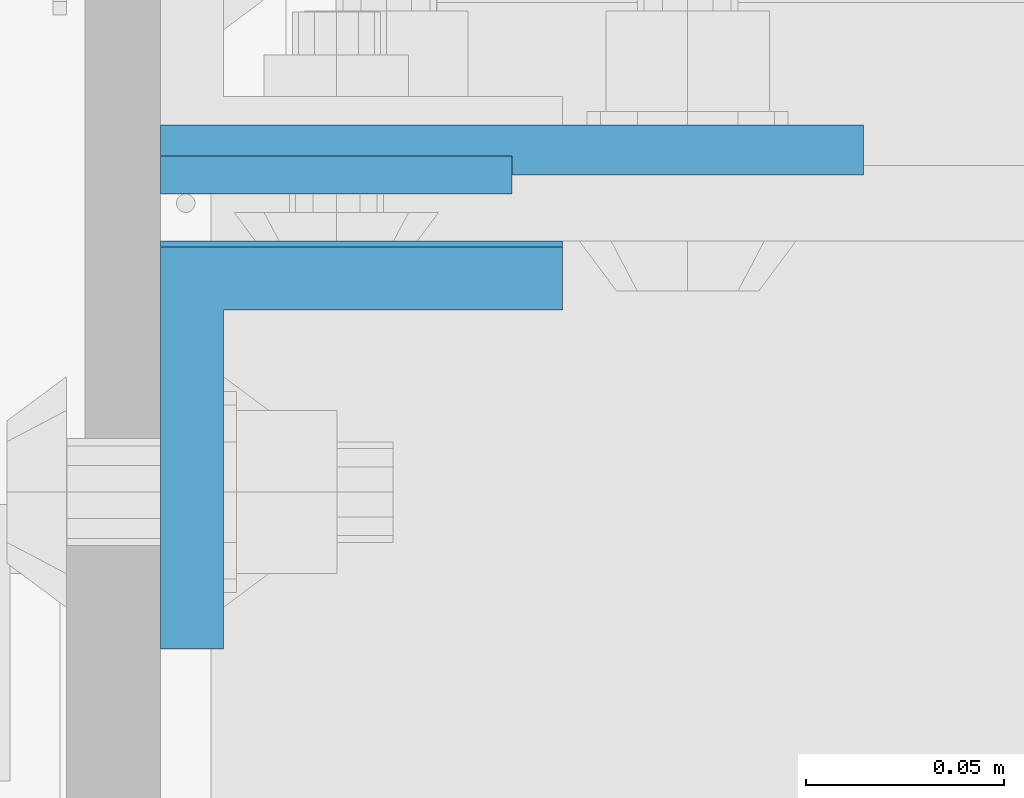
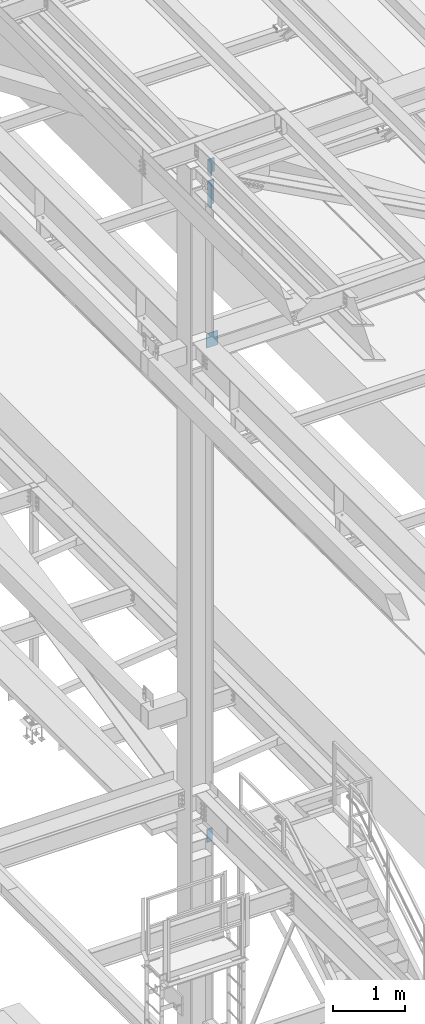
# One storey, part 1507 of 3843: 4 columns, 2 elements without a shape of their own.
"""IFC2X3 building model written with IfcOpenShell, lengths in millimetres."""

from ifc_helpers import new_model, si_unit, frame, origin_with_axes, place, context, subcontext, project, spatial, faceted_brep, material, type_object, element, aggregate, save


model = new_model("IFC2X3")

# Units and contexts
model_context = context("Model", 3, precision=1e-05, world=origin_with_axes())
body_context = subcontext(model_context, "Body", "Model", "MODEL_VIEW")
ifc_project = project(units=[si_unit("LENGTHUNIT", "METRE", prefix="MILLI"), si_unit("AREAUNIT", "SQUARE_METRE"), si_unit("VOLUMEUNIT", "CUBIC_METRE"), si_unit("MASSUNIT", "GRAM", prefix="KILO"), si_unit("TIMEUNIT", "SECOND"), si_unit("PLANEANGLEUNIT", "RADIAN"), si_unit("SOLIDANGLEUNIT", "STERADIAN"), si_unit("THERMODYNAMICTEMPERATUREUNIT", "DEGREE_CELSIUS"), si_unit("LUMINOUSINTENSITYUNIT", "LUMEN")], contexts=[model_context])

# Site, building, storey
site_placement = place(None, origin_with_axes())
site = spatial("IfcSite", under=ifc_project, at=site_placement, CompositionType="ELEMENT")
building_placement = place(site_placement, origin_with_axes())
building = spatial("IfcBuilding", under=site, at=building_placement, Name="Undefined", CompositionType="ELEMENT")
storey_placement = place(building_placement, origin_with_axes())
storey = spatial("IfcBuildingStorey", under=building, at=storey_placement, Name="Undefined", CompositionType="ELEMENT", Elevation=0.0)

# Assembly, columns
assembly_1_placement = place(storey_placement, origin_with_axes())
assembly_1 = element("IfcElementAssembly", 1, at=assembly_1_placement, inside=storey, Name="BEAM", AssemblyPlace="NOTDEFINED", PredefinedType="RIGID_FRAME")
ifc_material = material(Name="STEEL/A572-50")
column_type_1 = type_object("IfcColumnType", Name="L4X4X5/8", PredefinedType="NOTDEFINED")
column_1_placement = place(assembly_1_placement, frame((36810.95, 33785.1750003815, 44572.0221334664), z_axis=(0.0, -1.0, 0.0), x_axis=(0.0, 0.0, 1.0)))
column_1 = element("IfcColumn", 2, at=column_1_placement, type_object=column_type_1, material=ifc_material, Name="ANGLE", ObjectType="L4X4X5/8", context=body_context, shape_type="Brep", body=[
    faceted_brep([(0.0, 50.8000000000029, -50.8000000000029), (0.0, 50.8000000000029, 50.8000000000029), (406.399999999841, 50.799999998344, 50.8000000000029), (406.399999999841, 50.799999998344, -50.8000000000029), (0.0, 34.9250000000029, 50.8000000000029), (406.399999999892, 34.924999998344, 50.8000000000029), (0.0, 34.9250000000029, -34.9250000000029), (406.399999999892, 34.924999998344, -34.9250000000029), (0.0, -50.8000000000029, -34.9250000000029), (406.400000000162, -50.8000000016473, -34.9250000000029), (0.0, -50.8000000000029, -50.8000000000029), (406.400000000162, -50.8000000016473, -50.8000000000029)], [[[0, 1, 2, 3]], [[1, 4, 5, 2]], [[4, 6, 7, 5]], [[6, 8, 9, 7]], [[8, 10, 11, 9]], [[10, 0, 3, 11]], [[5, 7, 9, 11, 3, 2]], [[10, 8, 6, 4, 1, 0]]]),
])
column_2_placement = place(assembly_1_placement, frame((36810.9499999688, 33783.5879995346, 45113.5748965217), z_axis=(0.0, -1.0, 0.0), x_axis=(0.0, 0.0, 1.0)))
column_2 = element("IfcColumn", 3, at=column_2_placement, type_object=column_type_1, material=ifc_material, Name="ANGLE", ObjectType="L4X4X5/8", context=body_context, shape_type="Brep", body=[
    faceted_brep([(0.0, 50.8000000000029, -50.8000000000029), (0.0, 50.8000000000029, 50.8000000000029), (228.600164820818, 50.8000000000029, 50.8000000000029), (228.600164820818, 50.8000000000029, -50.8000000000029), (0.0, 34.9250000000029, 50.8000000000029), (228.600164820818, 34.9250000000029, 50.8000000000029), (0.0, 34.9250000000029, -34.9250000000029), (228.600164820818, 34.9250000000029, -34.9250000000029), (0.0, -50.8000000000029, -34.9250000000029), (228.600164820818, -50.8000000000029, -34.9250000000029), (0.0, -50.8000000000029, -50.8000000000029), (228.600164820818, -50.8000000000029, -50.8000000000029)], [[[0, 1, 2, 3]], [[1, 4, 5, 2]], [[4, 6, 7, 5]], [[6, 8, 9, 7]], [[8, 10, 11, 9]], [[10, 0, 3, 11]], [[5, 7, 9, 11, 3, 2]], [[10, 8, 6, 4, 1, 0]]]),
])
aggregate(assembly_1, [column_1, column_2])

assembly_2_placement = place(storey_placement, origin_with_axes())
assembly_2 = element("IfcElementAssembly", 4, at=assembly_2_placement, inside=storey, Name="COLUMN", AssemblyPlace="NOTDEFINED", PredefinedType="RIGID_FRAME")
column_type_2 = type_object("IfcColumnType", PredefinedType="NOTDEFINED")
column_3_placement = place(assembly_2_placement, frame((36849.0225000003, 33858.99375, 42132.3664980784), z_axis=(-1.0, 0.0, 0.0), x_axis=(0.0, 0.0, 1.0)))
column_3 = element("IfcColumn", 5, at=column_3_placement, type_object=column_type_2, material=ifc_material, Name="PLATE", context=body_context, shape_type="Brep", body=[
    faceted_brep([(0.0, 6.34999999999854, -88.8724999999977), (0.0, 6.34999999999854, 88.8724999999977), (241.299999999996, 6.34999999999854, 88.8724999999977), (241.299999999996, 6.34999999999854, -88.8724999999977), (0.0, -6.34999999999854, 88.8724999999977), (241.299999999996, -6.34999999999854, 88.8724999999977), (0.0, -6.34999999999854, -88.8724999999977), (241.299999999996, -6.34999999999854, -88.8724999999977)], [[[0, 1, 2, 3]], [[1, 4, 5, 2]], [[4, 6, 7, 5]], [[6, 0, 3, 7]], [[5, 7, 3, 2]], [[6, 4, 1, 0]]]),
])
column_type_3 = type_object("IfcColumnType", PredefinedType="NOTDEFINED")
column_4_placement = place(assembly_2_placement, frame((36804.6, 33852.64375, 33769.3), z_axis=(-1.0, 0.0, 0.0), x_axis=(0.0, 0.0, 1.0)))
column_4 = element("IfcColumn", 6, at=column_4_placement, type_object=column_type_3, material=ifc_material, Name="PLATE", context=body_context, shape_type="Brep", body=[
    faceted_brep([(0.0, 4.76249999999709, -44.4500000000007), (0.0, 4.76249999999709, 44.4500000000007), (228.599999999999, 4.76249999999709, 44.4500000000007), (228.599999999999, 4.76249999999709, -44.4500000000007), (0.0, -4.76249999999709, 44.4500000000007), (228.599999999999, -4.76249999999709, 44.4500000000007), (0.0, -4.76249999999709, -44.4500000000007), (228.599999999999, -4.76249999999709, -44.4500000000007)], [[[0, 1, 2, 3]], [[1, 4, 5, 2]], [[4, 6, 7, 5]], [[6, 0, 3, 7]], [[5, 7, 3, 2]], [[6, 4, 1, 0]]]),
])
aggregate(assembly_2, [column_3, column_4])

save(model, "model.ifc")
